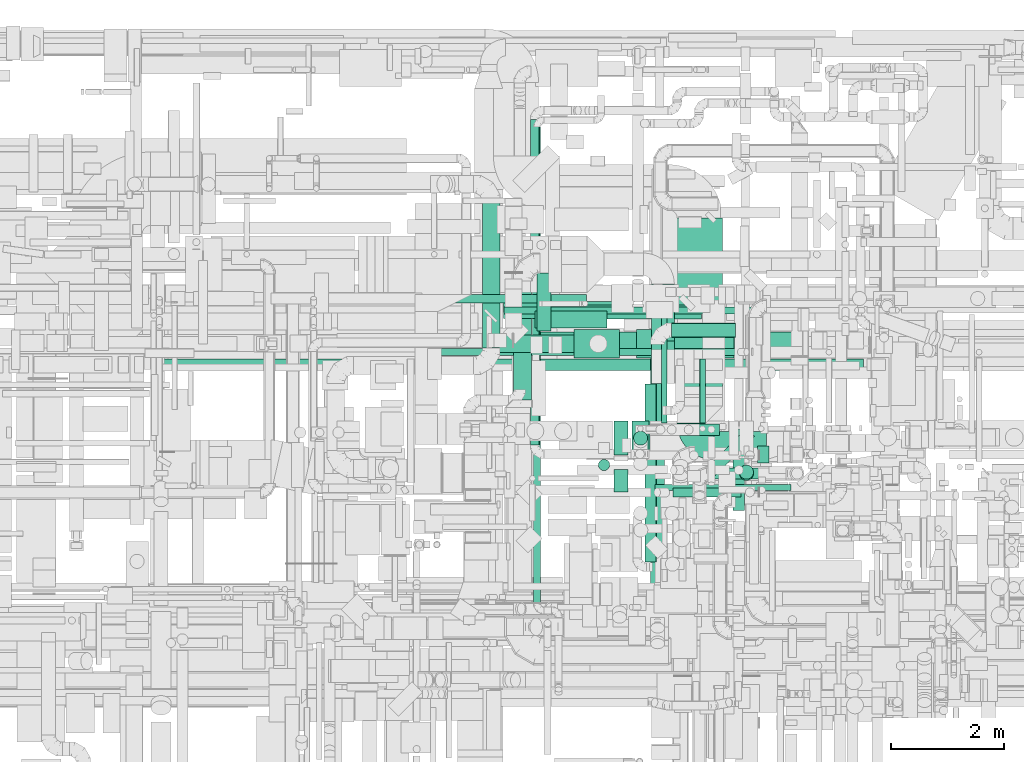
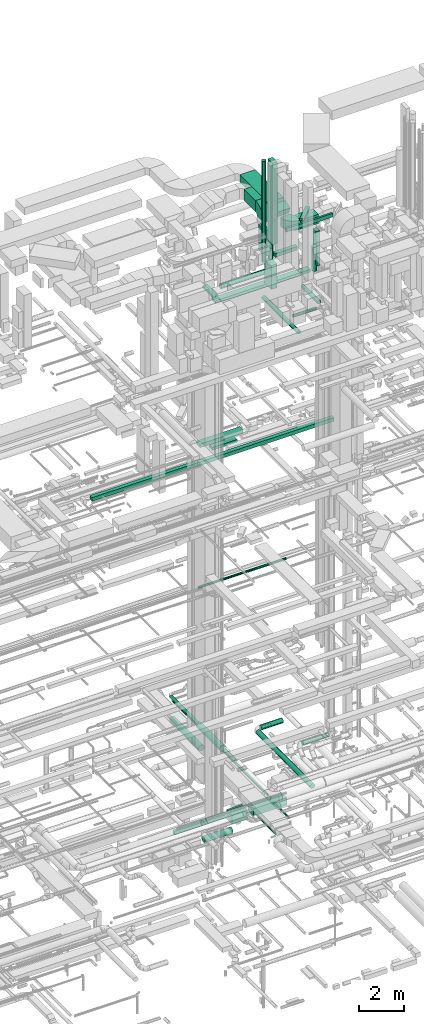
# One storey, part 47 of 337: 38 flow segments, 2 flow fittings.
"""IFC2X3 building model written with IfcOpenShell, lengths in millimetres."""

import ifcopenshell
import ifcopenshell.guid

model = None  # the IFC model being written
_history = None  # IfcOwnerHistory: only IFC2X3 demands one
_inside = {}  # id of a spatial element -> (the spatial element, [elements in it])
_under = {}  # id of a project, library or spatial element -> (it, [spatial elements below it])
_declared = {}  # id of a project -> (the project, [libraries it declares])
_typed = {}  # id of a type object -> (the type object, [elements of that type])
_made_of = {}  # id of a material, layer set ... -> (it, [elements and type objects made of it])


def new_model(schema):
    """Start an empty IFC model of exactly this schema.

    Asked for "IFC4X3", IfcOpenShell would pick the latest addendum, in which some entities
    have other attributes; the version numbers below select the first issue.
    IFC2X3 requires an IfcOwnerHistory on every rooted entity: one is made here for all.
    """
    global model, _history
    if schema == "IFC4X3":
        model = ifcopenshell.file(schema_version=(4, 3, 0, 0))
    else:
        model = ifcopenshell.file(schema=schema)
    _inside.clear()
    _under.clear()
    _declared.clear()
    _typed.clear()
    _made_of.clear()
    _history = None
    if model.schema == "IFC2X3":
        org = make("IfcOrganization", Name="unknown")
        user = make(
            "IfcPersonAndOrganization",
            ThePerson=make("IfcPerson", FamilyName="unknown"),
            TheOrganization=org,
        )
        app = make(
            "IfcApplication",
            ApplicationDeveloper=org,
            Version="unknown",
            ApplicationFullName="unknown",
            ApplicationIdentifier="unknown",
        )
        _history = make(
            "IfcOwnerHistory",
            OwningUser=user,
            OwningApplication=app,
            ChangeAction="ADDED",
            CreationDate=0,
        )
    return model


def make(cls, **values):
    """One entity of the class cls with the attributes given. An attribute that is None is left unset."""
    return model.create_entity(
        cls, **{name: value for name, value in values.items() if value is not None}
    )


def entity(cls, *values):
    """Any entity or typed value of the class cls, its attributes in the order of the schema. None: left unset."""
    e = model.create_entity(cls)
    for i, value in enumerate(values):
        if value is not None:
            e[i] = value
    return e


def rooted(cls, **values):
    """An entity with a GlobalId (a new one), such as an element, a storey or a relation."""
    return make(cls, GlobalId=ifcopenshell.guid.new(), OwnerHistory=_history, **values)


def si_unit(unit_type, name, prefix=None):
    """IfcSIUnit, for example si_unit("LENGTHUNIT", "METRE", prefix="MILLI")."""
    return make("IfcSIUnit", UnitType=unit_type, Prefix=prefix, Name=name)


def converted_unit(unit_type, name, factor, base, dimensions=None, offset=None):
    """IfcConversionBasedUnit, such as the inch: factor (a typed value) times the base unit."""
    return make(
        "IfcConversionBasedUnit"
        if offset is None
        else "IfcConversionBasedUnitWithOffset",
        ConversionOffset=offset,
        Dimensions=None
        if dimensions is None
        else entity("IfcDimensionalExponents", *dimensions),
        UnitType=unit_type,
        Name=name,
        ConversionFactor=make(
            "IfcMeasureWithUnit", ValueComponent=factor, UnitComponent=base
        ),
    )


def derived_unit(unit_type, elements):
    """IfcDerivedUnit: a product of units, each with its exponent."""
    return make(
        "IfcDerivedUnit",
        Elements=[
            make("IfcDerivedUnitElement", Unit=unit, Exponent=power)
            for unit, power in elements
        ],
        UnitType=unit_type,
    )


def assignment(units):
    """IfcUnitAssignment: the units of a project."""
    return None if units is None else make("IfcUnitAssignment", Units=units)


def point(xyz):
    """IfcCartesianPoint."""
    return None if xyz is None else make("IfcCartesianPoint", Coordinates=xyz)


def direction(xyz):
    """IfcDirection."""
    return None if xyz is None else make("IfcDirection", DirectionRatios=xyz)


def frame(location, z_axis=None, x_axis=None):
    """IfcAxis2Placement3D, a coordinate frame: its origin and axes. An axis left out is left unset."""
    return make(
        "IfcAxis2Placement3D",
        Location=point(location),
        Axis=direction(z_axis),
        RefDirection=direction(x_axis),
    )


def frame_2d(location, x_axis=None):
    """IfcAxis2Placement2D, a coordinate frame in the plane: its origin and x axis."""
    return make(
        "IfcAxis2Placement2D", Location=point(location), RefDirection=direction(x_axis)
    )


def origin():
    """The frame at (0, 0, 0) with its axes left unset."""
    return frame((0.0, 0.0, 0.0))


def origin_2d_with_axis():
    """The frame at (0, 0) in the plane with the x axis (1, 0) written out."""
    return frame_2d((0.0, 0.0), x_axis=(1.0, 0.0))


def place(relative_to, where):
    """IfcLocalPlacement: puts the frame where relative to a parent placement (None: the world)."""
    return make(
        "IfcLocalPlacement", PlacementRelTo=relative_to, RelativePlacement=where
    )


def context(
    kind, dimensions, precision=None, world=None, true_north=None, identifier=None
):
    """IfcGeometricRepresentationContext, for example the 3D "Model" context."""
    return make(
        "IfcGeometricRepresentationContext",
        ContextIdentifier=identifier,
        ContextType=kind,
        CoordinateSpaceDimension=dimensions,
        Precision=precision,
        WorldCoordinateSystem=world,
        TrueNorth=true_north,
    )


def subcontext(parent, identifier, kind, view, scale=None):
    """IfcGeometricRepresentationSubContext, for example "Body" below "Model"."""
    return make(
        "IfcGeometricRepresentationSubContext",
        ContextIdentifier=identifier,
        ContextType=kind,
        ParentContext=parent,
        TargetScale=scale,
        TargetView=view,
    )


def project(units=None, contexts=None):
    """IfcProject with its units and contexts."""
    return rooted(
        "IfcProject",
        Name="project",
        RepresentationContexts=contexts,
        UnitsInContext=assignment(units),
    )


def spatial(cls, under=None, at=None, **own):
    """A site, building, storey or space (cls), placed at a placement, below another one or the project."""
    s = rooted(cls, ObjectPlacement=at, **own)
    if under is not None:
        _under.setdefault(under.id(), (under, []))[1].append(s)
    return s


def polyline(points):
    """IfcPolyline through the points."""
    return make("IfcPolyline", Points=[point(p) for p in points])


def circle_curve(where, radius):
    """IfcCircle in the frame where."""
    return make("IfcCircle", Position=where, Radius=radius)


def parameter(value):
    """IfcParameterValue: where a trimmed curve begins or ends, as a parameter of its basis curve."""
    return model.create_entity("IfcParameterValue", value)


def trimmed(basis, trim1, trim2, sense, master):
    """IfcTrimmedCurve: the piece of a basis curve between two trims."""
    return make(
        "IfcTrimmedCurve",
        BasisCurve=basis,
        Trim1=trim1,
        Trim2=trim2,
        SenseAgreement=sense,
        MasterRepresentation=master,
    )


def segment(curve, same_sense, transition):
    """IfcCompositeCurveSegment."""
    return make(
        "IfcCompositeCurveSegment",
        Transition=transition,
        SameSense=same_sense,
        ParentCurve=curve,
    )


def composite_curve(segments, self_intersect=None):
    """IfcCompositeCurve: segments joined end to end."""
    return make("IfcCompositeCurve", Segments=segments, SelfIntersect=self_intersect)


def profile(cls, at=None, kind="AREA", **sizes):
    """A parametric profile (cls). Its sizes go by their IFC names, for example OverallWidth=200.0."""
    return make(cls, ProfileType=kind, Position=at, **sizes)


def rectangle(**sizes):
    """IfcRectangleProfileDef."""
    return profile("IfcRectangleProfileDef", **sizes)


def circle(**sizes):
    """IfcCircleProfileDef."""
    return profile("IfcCircleProfileDef", **sizes)


def outline(outer, holes=None, kind="AREA"):
    """IfcArbitraryClosedProfileDef: a profile drawn as a closed curve; with holes, ...WithVoids."""
    if holes is None:
        return make("IfcArbitraryClosedProfileDef", ProfileType=kind, OuterCurve=outer)
    return make(
        "IfcArbitraryProfileDefWithVoids",
        ProfileType=kind,
        OuterCurve=outer,
        InnerCurves=holes,
    )


def extrude(swept, where, along, depth):
    """IfcExtrudedAreaSolid: the profile swept, set in the frame where, extruded along a direction by depth."""
    return make(
        "IfcExtrudedAreaSolid",
        SweptArea=swept,
        Position=where,
        ExtrudedDirection=direction(along),
        Depth=depth,
    )


def shape(context_of_items, identifier, shape_type, items):
    """IfcShapeRepresentation: the items that make up one representation, for example the "Body"."""
    return make(
        "IfcShapeRepresentation",
        ContextOfItems=context_of_items,
        RepresentationIdentifier=identifier,
        RepresentationType=shape_type,
        Items=items,
    )


def source(mapping_origin, context_of_items, identifier, shape_type, items):
    """IfcRepresentationMap: a shape defined once, which mapped items show again and again."""
    return make(
        "IfcRepresentationMap",
        MappingOrigin=mapping_origin,
        MappedRepresentation=shape(context_of_items, identifier, shape_type, items),
    )


def transform(
    local_origin,
    x_axis=None,
    y_axis=None,
    z_axis=None,
    scale=None,
    scale2=None,
    scale3=None,
    uniform=True,
):
    """IfcCartesianTransformationOperator3D, or its non-uniform kind. x_axis, y_axis, z_axis: its Axis1, 2, 3."""
    if uniform:
        return make(
            "IfcCartesianTransformationOperator3D",
            Axis1=direction(x_axis),
            Axis2=direction(y_axis),
            LocalOrigin=point(local_origin),
            Scale=scale,
            Axis3=direction(z_axis),
        )
    return make(
        "IfcCartesianTransformationOperator3DnonUniform",
        Axis1=direction(x_axis),
        Axis2=direction(y_axis),
        LocalOrigin=point(local_origin),
        Scale=scale,
        Axis3=direction(z_axis),
        Scale2=scale2,
        Scale3=scale3,
    )


def mapped(mapping_source, mapping_target):
    """IfcMappedItem: shows the shape of a source again, moved by a transform."""
    return make(
        "IfcMappedItem", MappingSource=mapping_source, MappingTarget=mapping_target
    )


def material(Name=None, Category=None):
    """IfcMaterial."""
    return make("IfcMaterial", Name=Name, Category=Category)


def made_of(thing, what):
    """Note that an element or type object is made of a material, layer set ...; save() writes the relation."""
    if what is not None:
        _made_of.setdefault(what.id(), (what, []))[1].append(thing)
    return thing


def type_object(cls, material=None, **own):
    """A type object (cls), such as IfcWallType, which elements share."""
    return made_of(rooted(cls, **own), material)


def type_shapes(of_type, sources):
    """Give a type object the sources (RepresentationMaps) that its elements show as mapped items."""
    of_type.RepresentationMaps = sources


def element(
    cls,
    number,
    at=None,
    inside=None,
    cuts=None,
    type_object=None,
    material=None,
    context=None,
    identifier="Body",
    shape_type=None,
    held_by="IfcProductDefinitionShape",
    body=None,
    shapes=None,
    **own,
):
    """One element of the class cls, such as IfcWall. Its Tag is "e" and its number.

    at: its placement. inside: the storey or other place that contains it. cuts: it is an
    opening in that element (IfcRelVoidsElement). A single representation is given by context,
    identifier, shape_type and body (its items); several are given by shapes. held_by: the class
    of the entity that holds the representations. save() writes the other relations.
    """
    e = rooted(cls, Tag="e%d" % number, ObjectPlacement=at, **own)
    if body is not None:
        shapes = [shape(context, identifier, shape_type, body)]
    if shapes is not None:
        e.Representation = make(held_by, Representations=shapes)
    if inside is not None:
        _inside.setdefault(inside.id(), (inside, []))[1].append(e)
    if cuts is not None:
        rooted(
            "IfcRelVoidsElement", RelatingBuildingElement=cuts, RelatedOpeningElement=e
        )
    if type_object is not None:
        _typed.setdefault(type_object.id(), (type_object, []))[1].append(e)
    return made_of(e, material)


def aggregate(whole, parts):
    """IfcRelAggregates: a whole, such as a stair, and the parts it consists of."""
    return rooted("IfcRelAggregates", RelatingObject=whole, RelatedObjects=parts)


def save(model, path):
    """Write the relations noted so far, then the file.

    IfcRelAggregates (storeys below a building ...), IfcRelContainedInSpatialStructure (elements
    in a storey), IfcRelDefinesByType, IfcRelAssociatesMaterial and IfcRelDeclares: one each for
    every whole, place, type object, material and project.
    """
    for whole, parts in _under.values():
        aggregate(whole, parts)
    for where, things in _inside.values():
        rooted(
            "IfcRelContainedInSpatialStructure",
            RelatedElements=things,
            RelatingStructure=where,
        )
    for kind, things in _typed.values():
        rooted("IfcRelDefinesByType", RelatedObjects=things, RelatingType=kind)
    for what, things in _made_of.values():
        rooted("IfcRelAssociatesMaterial", RelatedObjects=things, RelatingMaterial=what)
    for by, libraries in _declared.values():
        rooted("IfcRelDeclares", RelatingContext=by, RelatedDefinitions=libraries)
    model.write(path)


model = new_model("IFC2X3")

# Units and contexts
model_context = context("Model", 3, precision=0.01, world=origin(), true_north=direction((6.12303176911189e-17, 1.0)))
body_context = subcontext(model_context, "Body", "Model", "MODEL_VIEW")
ifc_project = project(units=[si_unit("LENGTHUNIT", "METRE", prefix="MILLI"), si_unit("AREAUNIT", "SQUARE_METRE"), si_unit("VOLUMEUNIT", "CUBIC_METRE"), converted_unit("PLANEANGLEUNIT", "DEGREE", entity("IfcRatioMeasure", 0.0174532925199433), si_unit("PLANEANGLEUNIT", "RADIAN"), dimensions=[0, 0, 0, 0, 0, 0, 0]), si_unit("MASSUNIT", "GRAM", prefix="KILO"), derived_unit("MASSDENSITYUNIT", [(si_unit("MASSUNIT", "GRAM", prefix="KILO"), 1), (si_unit("LENGTHUNIT", "METRE"), -3)]), derived_unit("MOMENTOFINERTIAUNIT", [(si_unit("LENGTHUNIT", "METRE"), 4)]), si_unit("TIMEUNIT", "SECOND"), si_unit("FREQUENCYUNIT", "HERTZ"), si_unit("THERMODYNAMICTEMPERATUREUNIT", "DEGREE_CELSIUS"), derived_unit("THERMALTRANSMITTANCEUNIT", [(si_unit("MASSUNIT", "GRAM", prefix="KILO"), 1), (si_unit("THERMODYNAMICTEMPERATUREUNIT", "KELVIN"), -1), (si_unit("TIMEUNIT", "SECOND"), -3)]), derived_unit("VOLUMETRICFLOWRATEUNIT", [(si_unit("LENGTHUNIT", "METRE"), 3), (si_unit("TIMEUNIT", "SECOND"), -1)]), derived_unit("MASSFLOWRATEUNIT", [(si_unit("MASSUNIT", "GRAM", prefix="KILO"), 1), (si_unit("TIMEUNIT", "SECOND"), -1)]), derived_unit("ROTATIONALFREQUENCYUNIT", [(si_unit("TIMEUNIT", "SECOND"), -1)]), si_unit("ELECTRICCURRENTUNIT", "AMPERE"), si_unit("ELECTRICVOLTAGEUNIT", "VOLT"), si_unit("POWERUNIT", "WATT"), si_unit("FORCEUNIT", "NEWTON", prefix="KILO"), si_unit("ILLUMINANCEUNIT", "LUX"), si_unit("LUMINOUSFLUXUNIT", "LUMEN"), si_unit("LUMINOUSINTENSITYUNIT", "CANDELA"), derived_unit("USERDEFINED", [(si_unit("MASSUNIT", "GRAM", prefix="KILO"), -1), (si_unit("LENGTHUNIT", "METRE"), -2), (si_unit("TIMEUNIT", "SECOND"), 3), (si_unit("LUMINOUSFLUXUNIT", "LUMEN"), 1)]), derived_unit("LINEARVELOCITYUNIT", [(si_unit("LENGTHUNIT", "METRE"), 1), (si_unit("TIMEUNIT", "SECOND"), -1)]), si_unit("PRESSUREUNIT", "PASCAL"), derived_unit("USERDEFINED", [(si_unit("LENGTHUNIT", "METRE"), -2), (si_unit("MASSUNIT", "GRAM", prefix="KILO"), 1), (si_unit("TIMEUNIT", "SECOND"), -2)]), derived_unit("LINEARFORCEUNIT", [(si_unit("MASSUNIT", "GRAM", prefix="KILO"), 1), (si_unit("LENGTHUNIT", "METRE"), 1), (si_unit("TIMEUNIT", "SECOND"), -2), (si_unit("LENGTHUNIT", "METRE"), -1)]), derived_unit("PLANARFORCEUNIT", [(si_unit("MASSUNIT", "GRAM", prefix="KILO"), 1), (si_unit("LENGTHUNIT", "METRE"), 1), (si_unit("TIMEUNIT", "SECOND"), -2), (si_unit("LENGTHUNIT", "METRE"), -2)])], contexts=[model_context])

# Site, building, storey
site_placement = place(None, origin())
site = spatial("IfcSite", under=ifc_project, at=site_placement, CompositionType="ELEMENT")
building_placement = place(site_placement, origin())
building = spatial("IfcBuilding", under=site, at=building_placement, CompositionType="ELEMENT")
storey_placement = place(building_placement, origin())
storey = spatial("IfcBuildingStorey", under=building, at=storey_placement, CompositionType="ELEMENT", Elevation=0.0)

# Flow segments
duct_segment_type_1 = type_object("IfcDuctSegmentType", PredefinedType="NOTDEFINED")
flow_segment_1_placement = place(storey_placement, frame((45445.8, 15273.96, -1700.0)))
element("IfcFlowSegment", 1, at=flow_segment_1_placement, inside=storey, type_object=duct_segment_type_1, context=body_context, shape_type="SweptSolid", body=[
    extrude(rectangle(XDim=2608.91080650002, YDim=150.000000000001, at=origin_2d_with_axis()), frame((1304.46, 75.0, 0.0)), (0.0, 0.0, 1.0), 200.0),
])
flow_segment_2_placement = place(storey_placement, frame((47835.87, 14298.39, -1350.0)))
element("IfcFlowSegment", 2, at=flow_segment_2_placement, inside=storey, type_object=duct_segment_type_1, context=body_context, shape_type="SweptSolid", body=[
    extrude(rectangle(XDim=809.235435250011, YDim=499.999999999999, at=origin_2d_with_axis()), frame((404.62, 250.0, 0.0)), (0.0, 0.0, 1.0), 500.0),
])
flow_segment_3_placement = place(storey_placement, frame((48945.11, 14298.39, -1300.0)))
element("IfcFlowSegment", 3, at=flow_segment_3_placement, inside=storey, type_object=duct_segment_type_1, context=body_context, shape_type="SweptSolid", body=[
    extrude(rectangle(XDim=1725.0016408126, YDim=499.999999999999, at=origin_2d_with_axis()), frame((862.5, 250.0, 0.0)), (0.0, 0.0, 1.0), 400.0),
])
flow_segment_4_placement = place(storey_placement, frame((47144.3, 14825.52, 18900.0)))
element("IfcFlowSegment", 4, at=flow_segment_4_placement, inside=storey, type_object=duct_segment_type_1, context=body_context, shape_type="SweptSolid", body=[
    extrude(rectangle(XDim=1275.73593128808, YDim=299.999999999999, at=origin_2d_with_axis()), frame((637.87, 150.0, 0.0), z_axis=(0.0, 0.0, 1.0), x_axis=(-1.0, 0.0, 0.0)), (0.0, 0.0, 1.0), 150.000000000001),
])
flow_segment_5_placement = place(storey_placement, frame((46591.69, 14998.63, 19125.02)))
element("IfcFlowSegment", 5, at=flow_segment_5_placement, inside=storey, type_object=duct_segment_type_1, context=body_context, shape_type="SweptSolid", body=[
    extrude(rectangle(XDim=2222.20862076596, YDim=300.000000000001, at=origin_2d_with_axis()), frame((1111.1, 150.0, 0.0), z_axis=(0.0, 0.0, 1.0), x_axis=(-1.0, 0.0, 0.0)), (0.0, 0.0, 1.0), 200.000000000002),
])
flow_segment_6_placement = place(storey_placement, frame((40511.98, 14075.53, 18900.0)))
element("IfcFlowSegment", 6, at=flow_segment_6_placement, inside=storey, type_object=duct_segment_type_1, context=body_context, shape_type="SweptSolid", body=[
    extrude(rectangle(XDim=12453.6489488776, YDim=200.0, at=origin_2d_with_axis()), frame((6226.82, 100.0, 0.0), z_axis=(0.0, 0.0, 1.0), x_axis=(-1.0, 0.0, 0.0)), (0.0, 0.0, 1.0), 200.000000000002),
])
flow_segment_7_placement = place(storey_placement, frame((47183.77, 14776.21, 27150.0)))
element("IfcFlowSegment", 7, at=flow_segment_7_placement, inside=storey, type_object=duct_segment_type_1, context=body_context, shape_type="SweptSolid", body=[
    extrude(rectangle(XDim=1027.50000000001, YDim=250.000000000004, at=origin_2d_with_axis()), frame((125.0, 513.75, 0.0), z_axis=(0.0, 0.0, 1.0), x_axis=(0.0, 1.0, 0.0)), (0.0, 0.0, 1.0), 100.000000000003),
])
flow_segment_8_placement = place(storey_placement, frame((47071.44, 14456.21, 27125.0)))
element("IfcFlowSegment", 8, at=flow_segment_8_placement, inside=storey, type_object=duct_segment_type_1, context=body_context, shape_type="SweptSolid", body=[
    extrude(rectangle(XDim=4900.78515046475, YDim=300.000000000001, at=origin_2d_with_axis()), frame((2450.39, 150.0, 0.0), z_axis=(0.0, 0.0, 1.0), x_axis=(-1.0, 0.0, 0.0)), (0.0, 0.0, 1.0), 150.000000000001),
])
flow_segment_9_placement = place(storey_placement, frame((48867.58, 12574.75, 28400.0)))
element("IfcFlowSegment", 9, at=flow_segment_9_placement, inside=storey, type_object=duct_segment_type_1, context=body_context, shape_type="SweptSolid", body=[
    extrude(rectangle(XDim=300.000000000001, YDim=600.0, at=origin_2d_with_axis()), frame((150.0, 300.0, 0.0)), (0.0, 0.0, 1.0), 1294.5),
])
flow_segment_10_placement = place(storey_placement, frame((49260.78, 12924.99, 29799.32)))
element("IfcFlowSegment", 10, at=flow_segment_10_placement, inside=storey, type_object=duct_segment_type_1, context=body_context, shape_type="SweptSolid", body=[
    extrude(rectangle(XDim=1157.50000000003, YDim=200.0, at=origin_2d_with_axis()), frame((578.75, 100.0, 0.0), z_axis=(0.0, 0.0, 1.0), x_axis=(-1.0, 0.0, 0.0)), (0.0, 0.0, 1.0), 199.999999999998),
])
flow_segment_11_placement = place(storey_placement, frame((48542.04, 12574.75, 30300.0)))
element("IfcFlowSegment", 11, at=flow_segment_11_placement, inside=storey, type_object=duct_segment_type_1, context=body_context, shape_type="SweptSolid", body=[
    extrude(rectangle(XDim=249.999999999995, YDim=600.0, at=origin_2d_with_axis()), frame((125.0, 300.0, 0.0)), (0.0, 0.0, 1.0), 1400.0),
])
flow_segment_12_placement = place(storey_placement, frame((48542.04, 11917.5, 31330.0)))
element("IfcFlowSegment", 12, at=flow_segment_12_placement, inside=storey, type_object=duct_segment_type_1, context=body_context, shape_type="SweptSolid", body=[
    extrude(rectangle(XDim=400.0, YDim=250.000000000004, at=origin_2d_with_axis()), frame((125.0, 200.0, 0.0), z_axis=(0.0, 0.0, 1.0), x_axis=(0.0, -1.0, 0.0)), (0.0, 0.0, 1.0), 4456.99997500064),
])
flow_segment_13_placement = place(storey_placement, frame((49665.39, 14273.86, 31430.26)))
element("IfcFlowSegment", 13, at=flow_segment_13_placement, inside=storey, type_object=duct_segment_type_1, context=body_context, shape_type="SweptSolid", body=[
    extrude(rectangle(XDim=2498.43288166948, YDim=800.0, at=origin_2d_with_axis()), frame((400.0, 1249.22, 0.0), z_axis=(0.0, 0.0, 1.0), x_axis=(0.0, -1.0, 0.0)), (0.0, 0.0, 1.0), 400.000000000004),
])
flow_segment_14_placement = place(storey_placement, frame((49665.39, 13649.75, 31256.48)))
element("IfcFlowSegment", 14, at=flow_segment_14_placement, inside=storey, type_object=duct_segment_type_1, context=body_context, shape_type="SweptSolid", body=[
    extrude(rectangle(XDim=400.000000000002, YDim=457.501441613444, at=frame_2d((0.0, 0.0), x_axis=(0.0, 1.0))), frame((0.0, 285.2, 268.65), z_axis=(1.0, 0.0, 0.0), x_axis=(0.0, -0.933679897750566, -0.358108710500725)), (0.0, 0.0, 1.0), 799.999999999991),
])
flow_segment_15_placement = place(storey_placement, frame((50315.39, 12491.6, 31220.0)))
element("IfcFlowSegment", 15, at=flow_segment_15_placement, inside=storey, type_object=duct_segment_type_1, context=body_context, shape_type="SweptSolid", body=[
    extrude(rectangle(XDim=929.820331649733, YDim=500.000000000001, at=origin_2d_with_axis()), frame((464.91, 250.0, 0.0)), (0.0, 0.0, 1.0), 499.999999999999),
])
flow_segment_16_placement = place(storey_placement, frame((49214.76, 14594.03, 31300.0)))
element("IfcFlowSegment", 16, at=flow_segment_16_placement, inside=storey, type_object=duct_segment_type_1, context=body_context, shape_type="SweptSolid", body=[
    extrude(rectangle(XDim=1010.60447130812, YDim=399.999999999996, at=origin_2d_with_axis()), frame((200.0, 505.3, 0.0), z_axis=(0.0, 0.0, 1.0), x_axis=(0.0, -1.0, 0.0)), (0.0, 0.0, 1.0), 600.000000000002),
])
flow_segment_17_placement = place(storey_placement, frame((51089.86, 12435.89, 28950.0)))
element("IfcFlowSegment", 17, at=flow_segment_17_placement, inside=storey, type_object=duct_segment_type_1, context=body_context, shape_type="SweptSolid", body=[
    extrude(rectangle(XDim=200.000000000007, YDim=299.999999999999, at=origin_2d_with_axis()), frame((100.0, 150.0, 0.0), z_axis=(0.0, 0.0, 1.0), x_axis=(-1.0, 0.0, 0.0)), (0.0, 0.0, 1.0), 1900.00002499999),
])
flow_segment_18_placement = place(storey_placement, frame((50187.12, 12201.99, 31850.0)))
element("IfcFlowSegment", 18, at=flow_segment_18_placement, inside=storey, type_object=duct_segment_type_1, context=body_context, shape_type="SweptSolid", body=[
    extrude(rectangle(XDim=1000.88038169478, YDim=199.999999999993, at=origin_2d_with_axis()), frame((424.58, 424.58, 0.0), z_axis=(0.0, 0.0, 1.0), x_axis=(0.707106781186548, 0.707106781186548, 0.0)), (0.0, 0.0, 1.0), 100.000000000003),
])
flow_segment_19_placement = place(storey_placement, frame((49273.0, 11949.48, 31750.0)))
element("IfcFlowSegment", 19, at=flow_segment_19_placement, inside=storey, type_object=duct_segment_type_1, context=body_context, shape_type="SweptSolid", body=[
    extrude(rectangle(XDim=2409.07003346177, YDim=99.9999999999989, at=origin_2d_with_axis()), frame((1204.54, 50.0, 0.0)), (0.0, 0.0, 1.0), 199.999999999998),
])
duct_segment_type_2 = type_object("IfcDuctSegmentType", PredefinedType="NOTDEFINED")
flow_segment_20_placement = place(storey_placement, frame((46510.2, 14389.3, -2024.1)))
element("IfcFlowSegment", 20, at=flow_segment_20_placement, inside=storey, type_object=duct_segment_type_2, context=body_context, shape_type="SweptSolid", body=[
    extrude(circle(Radius=157.5, at=origin_2d_with_axis()), frame((0.0, 159.1, 159.1), z_axis=(1.0, 0.0, 0.0), x_axis=(0.0, 1.0, 0.0)), (0.0, 0.0, 1.0), 1442.4659625),
])
flow_segment_21_placement = place(storey_placement, frame((46595.61, 15074.19, 11385.9)))
element("IfcFlowSegment", 21, at=flow_segment_21_placement, inside=storey, type_object=duct_segment_type_2, context=body_context, shape_type="SweptSolid", body=[
    extrude(circle(Radius=62.5, at=origin_2d_with_axis()), frame((0.0, 64.1, 64.1), z_axis=(1.0, 0.0, 0.0), x_axis=(0.0, -1.0, 0.0)), (0.0, 0.0, 1.0), 4500.0),
])
flow_segment_22_placement = place(storey_placement, frame((46763.62, 13552.42, 3390.9)))
element("IfcFlowSegment", 22, at=flow_segment_22_placement, inside=storey, type_object=duct_segment_type_2, context=body_context, shape_type="SweptSolid", body=[
    extrude(circle(Radius=157.5, at=origin_2d_with_axis()), frame((159.1, 0.0, 159.1), z_axis=(0.0, 1.0, 0.0), x_axis=(-1.0, 0.0, 0.0)), (0.0, 0.0, 1.0), 2110.00000000002),
])
flow_segment_23_placement = place(storey_placement, frame((46212.49, 14475.95, 3040.9)))
element("IfcFlowSegment", 23, at=flow_segment_23_placement, inside=storey, type_object=duct_segment_type_2, context=body_context, shape_type="SweptSolid", body=[
    extrude(circle(Radius=157.5, at=origin_2d_with_axis()), frame((159.1, 0.0, 159.1), z_axis=(0.0, 1.0, 0.0), x_axis=(-1.0, 0.0, 0.0)), (0.0, 0.0, 1.0), 2583.32701766454),
])
flow_segment_24_placement = place(storey_placement, frame((49192.74, 9693.88, 2873.4)))
element("IfcFlowSegment", 24, at=flow_segment_24_placement, inside=storey, type_object=duct_segment_type_2, context=body_context, shape_type="SweptSolid", body=[
    extrude(circle(Radius=125.0, at=origin_2d_with_axis()), frame((126.6, 0.0, 126.6), z_axis=(3.59378935640593e-08, 1.0, 0.0), x_axis=(-1.0, 3.59378935640593e-08, 0.0)), (0.0, 0.0, 1.0), 4842.28639121507),
])
flow_segment_25_placement = place(storey_placement, frame((49569.33, 14659.57, 2873.4)))
element("IfcFlowSegment", 25, at=flow_segment_25_placement, inside=storey, type_object=duct_segment_type_2, context=body_context, shape_type="SweptSolid", body=[
    extrude(circle(Radius=125.0, at=origin_2d_with_axis()), frame((0.0, 126.6, 126.6), z_axis=(1.0, 0.0, 0.0), x_axis=(0.0, -1.0, 0.0)), (0.0, 0.0, 1.0), 1130.0),
])
flow_segment_26_placement = place(storey_placement, frame((50262.54, 12147.45, 3348.4)))
element("IfcFlowSegment", 26, at=flow_segment_26_placement, inside=storey, type_object=duct_segment_type_2, context=body_context, shape_type="SweptSolid", body=[
    extrude(circle(Radius=100.0, at=origin_2d_with_axis()), frame((0.0, 101.6, 101.6), z_axis=(1.0, 0.0, 0.0), x_axis=(0.0, 1.0, 0.0)), (0.0, 0.0, 1.0), 1329.17500000001),
])
flow_segment_27_placement = place(storey_placement, frame((50655.03, 11595.58, 27548.4)))
element("IfcFlowSegment", 27, at=flow_segment_27_placement, inside=storey, type_object=duct_segment_type_2, context=body_context, shape_type="SweptSolid", body=[
    extrude(circle(Radius=100.0, at=origin_2d_with_axis()), frame((101.6, 0.0, 101.6), z_axis=(0.0, 1.0, 0.0), x_axis=(1.0, 0.0, 0.0)), (0.0, 0.0, 1.0), 1444.99999999998),
])
flow_segment_28_placement = place(storey_placement, frame((47706.43, 14986.5, 27323.4)))
element("IfcFlowSegment", 28, at=flow_segment_28_placement, inside=storey, type_object=duct_segment_type_2, context=body_context, shape_type="SweptSolid", body=[
    extrude(circle(Radius=125.0, at=origin_2d_with_axis()), frame((0.0, 126.6, 126.6), z_axis=(1.0, 0.0, 0.0), x_axis=(0.0, -1.0, 0.0)), (0.0, 0.0, 1.0), 2390.01849185172),
])
flow_segment_29_placement = place(storey_placement, frame((49094.22, 10682.22, 27013.11)))
element("IfcFlowSegment", 29, at=flow_segment_29_placement, inside=storey, type_object=duct_segment_type_2, context=body_context, shape_type="SweptSolid", body=[
    extrude(circle(Radius=100.0, at=origin_2d_with_axis()), frame((101.6, 0.0, 101.6), z_axis=(0.0, 1.0, 0.0), x_axis=(-1.0, 0.0, 0.0)), (0.0, 0.0, 1.0), 3152.04898539802),
])
flow_segment_30_placement = place(storey_placement, frame((49587.36, 11833.6, 27033.11)))
element("IfcFlowSegment", 30, at=flow_segment_30_placement, inside=storey, type_object=duct_segment_type_2, context=body_context, shape_type="SweptSolid", body=[
    extrude(circle(Radius=80.0, at=origin_2d_with_axis()), frame((0.0, 81.6, 81.6), z_axis=(1.0, 0.0, 0.0), x_axis=(0.0, 1.0, 0.0)), (0.0, 0.0, 1.0), 1205.51351310696),
])
flow_segment_31_placement = place(storey_placement, frame((48268.51, 12298.4, 30225.0)))
element("IfcFlowSegment", 31, at=flow_segment_31_placement, inside=storey, type_object=duct_segment_type_2, context=body_context, shape_type="SweptSolid", body=[
    extrude(circle(Radius=100.0, at=origin_2d_with_axis()), frame((101.6, 101.6, 0.0)), (0.0, 0.0, 1.0), 5500.00000000001),
])
flow_segment_32_placement = place(storey_placement, frame((48890.99, 12748.15, 29894.5)))
element("IfcFlowSegment", 32, at=flow_segment_32_placement, inside=storey, type_object=duct_segment_type_2, context=body_context, shape_type="SweptSolid", body=[
    extrude(circle(Radius=125.0, at=origin_2d_with_axis()), frame((126.6, 126.6, 0.0), z_axis=(0.0, 0.0, 1.0), x_axis=(0.0, 1.0, 0.0)), (0.0, 0.0, 1.0), 1350.07633433927),
])
flow_segment_33_placement = place(storey_placement, frame((50767.08, 12122.47, 28950.55)))
element("IfcFlowSegment", 33, at=flow_segment_33_placement, inside=storey, type_object=duct_segment_type_2, context=body_context, shape_type="SweptSolid", body=[
    extrude(circle(Radius=125.0, at=origin_2d_with_axis()), frame((126.6, 126.58, 3.78), z_axis=(0.0, 0.0174524064372837, 0.999847695156391), x_axis=(0.0, 0.999847695156391, -0.0174524064372837)), (0.0, 0.0, 1.0), 1302.24635289908),
])
flow_segment_34_placement = place(storey_placement, frame((47061.74, 12753.92, 3198.4)))
element("IfcFlowSegment", 34, at=flow_segment_34_placement, inside=storey, type_object=duct_segment_type_2, context=body_context, shape_type="SweptSolid", body=[
    extrude(circle(Radius=80.0, at=origin_2d_with_axis()), frame((81.6, 0.0, 81.6), z_axis=(0.0, 1.0, 0.0), x_axis=(1.0, 0.0, 0.0)), (0.0, 0.0, 1.0), 5765.19448651334),
])
flow_segment_35_placement = place(storey_placement, frame((47120.5, 9947.51, 3035.9)))
element("IfcFlowSegment", 35, at=flow_segment_35_placement, inside=storey, type_object=duct_segment_type_2, context=body_context, shape_type="SweptSolid", body=[
    extrude(circle(Radius=62.5, at=origin_2d_with_axis()), frame((64.1, 0.0, 64.1), z_axis=(0.0, 1.0, 0.0), x_axis=(-1.0, 0.0, 0.0)), (0.0, 0.0, 1.0), 8436.60000000003),
])
flow_segment_36_placement = place(storey_placement, frame((49387.5, 13143.4, -1801.6)))
element("IfcFlowSegment", 36, at=flow_segment_36_placement, inside=storey, type_object=duct_segment_type_2, context=body_context, shape_type="SweptSolid", body=[
    extrude(circle(Radius=50.0, at=origin_2d_with_axis()), frame((51.6, 0.0, 51.6), z_axis=(0.0, 1.0, 0.0), x_axis=(1.0, 0.0, 0.0)), (0.0, 0.0, 1.0), 1935.55322000039),
])
flow_segment_37_placement = place(storey_placement, frame((50063.03, 13143.39, -1151.6)))
element("IfcFlowSegment", 37, at=flow_segment_37_placement, inside=storey, type_object=duct_segment_type_2, context=body_context, shape_type="SweptSolid", body=[
    extrude(circle(Radius=50.0, at=origin_2d_with_axis()), frame((51.6, 0.0, 51.6), z_axis=(0.0, 1.0, 0.0), x_axis=(1.0, 0.0, 0.0)), (0.0, 0.0, 1.0), 1135.00103000001),
])
flow_segment_38_placement = place(storey_placement, frame((45070.15, 14338.22, -764.1)))
element("IfcFlowSegment", 38, at=flow_segment_38_placement, inside=storey, type_object=duct_segment_type_2, context=body_context, shape_type="SweptSolid", body=[
    extrude(circle(Radius=62.5, at=origin_2d_with_axis()), frame((0.0, 64.1, 64.1), z_axis=(1.0, 0.0, 0.0), x_axis=(0.0, 1.0, 0.0)), (0.0, 0.0, 1.0), 5618.7203007033),
])

# Flow fittings
ifc_material = material()
duct_fitting_type_1 = type_object("IfcDuctFittingType", PredefinedType="NOTDEFINED", material=ifc_material)
shared_shape_1 = source(origin(), body_context, "Body", "SweptSolid", [
    extrude(outline(composite_curve([segment(polyline([(-525.0, -225.0), (75.0, -225.0)]), True, "CONTINUOUS"), segment(trimmed(circle_curve(frame_2d((225.0, -225.0), x_axis=(0.0, 1.0)), 150.0), [parameter(0.0)], [parameter(90.0)], True, "PARAMETER"), False, "CONTINUOUS"), segment(polyline([(225.0, -75.0), (225.0, 525.0)]), True, "CONTINUOUS"), segment(trimmed(circle_curve(frame_2d((225.0, -225.0), x_axis=(0.0, 1.0)), 750.0), [parameter(0.0)], [parameter(90.0)], True, "PARAMETER"), True, "CONTINUOUS")], self_intersect=False)), frame((-225.0, 225.0, -200.0), z_axis=(0.0, 0.0, 1.0), x_axis=(-1.0, 0.0, 0.0)), (0.0, 0.0, 1.0), 400.0),
])
type_shapes(duct_fitting_type_1, [shared_shape_1])
flow_fitting_1_placement = place(storey_placement, frame((49414.76, 14144.03, 31600.0), z_axis=(1.0, 0.0, 0.0), x_axis=(0.0, -1.0, 0.0)))
element("IfcFlowFitting", 39, at=flow_fitting_1_placement, inside=storey, type_object=duct_fitting_type_1, material=ifc_material, context=body_context, shape_type="MappedRepresentation", body=[
    mapped(shared_shape_1, transform((0.0, 0.0, 0.0), scale=1.0)),
])
duct_fitting_type_2 = type_object("IfcDuctFittingType", PredefinedType="NOTDEFINED", material=ifc_material)
shared_shape_2 = source(origin(), body_context, "Body", "SweptSolid", [
    extrude(outline(composite_curve([segment(polyline([(-450.0, -200.0), (50.0, -200.0)]), True, "CONTINUOUS"), segment(trimmed(circle_curve(frame_2d((200.0, -200.0), x_axis=(0.0, 1.0)), 150.0), [parameter(0.0)], [parameter(90.0000000000001)], True, "PARAMETER"), False, "CONTINUOUS"), segment(polyline([(200.0, -50.0), (200.0, 450.0)]), True, "CONTINUOUS"), segment(trimmed(circle_curve(frame_2d((200.0, -200.0), x_axis=(0.0, 1.0)), 650.0), [parameter(0.0)], [parameter(90.0000000000001)], True, "PARAMETER"), True, "CONTINUOUS")], self_intersect=False)), frame((-200.0, 200.0, -250.0), z_axis=(0.0, 0.0, 1.0), x_axis=(-1.0, 0.0, 0.0)), (0.0, 0.0, 1.0), 500.0),
])
type_shapes(duct_fitting_type_2, [shared_shape_2])
flow_fitting_2_placement = place(storey_placement, frame((49915.39, 12741.6, 31470.0), z_axis=(0.0, 0.0, 1.0), x_axis=(0.0, -1.0, 0.0)))
element("IfcFlowFitting", 40, at=flow_fitting_2_placement, inside=storey, type_object=duct_fitting_type_2, material=ifc_material, context=body_context, shape_type="MappedRepresentation", body=[
    mapped(shared_shape_2, transform((0.0, 0.0, 0.0), scale=1.0)),
])

save(model, "model.ifc")
